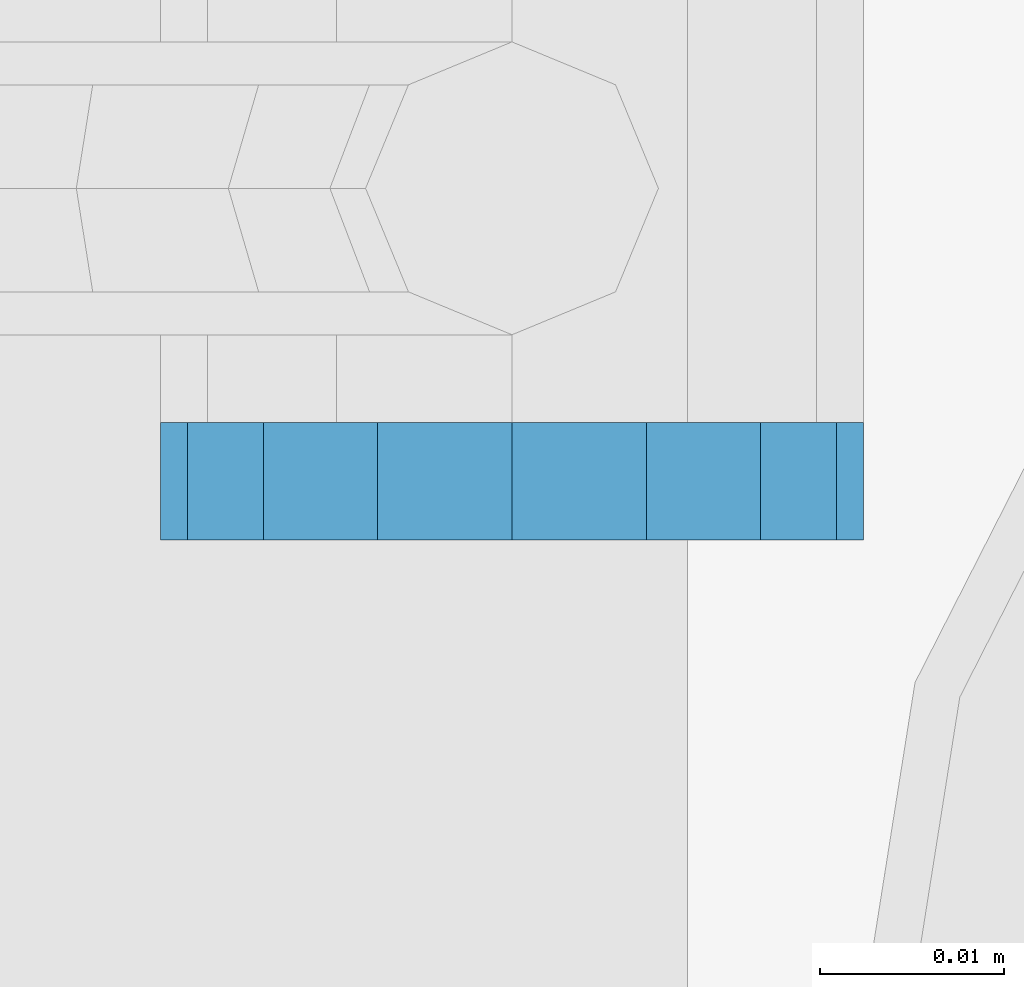
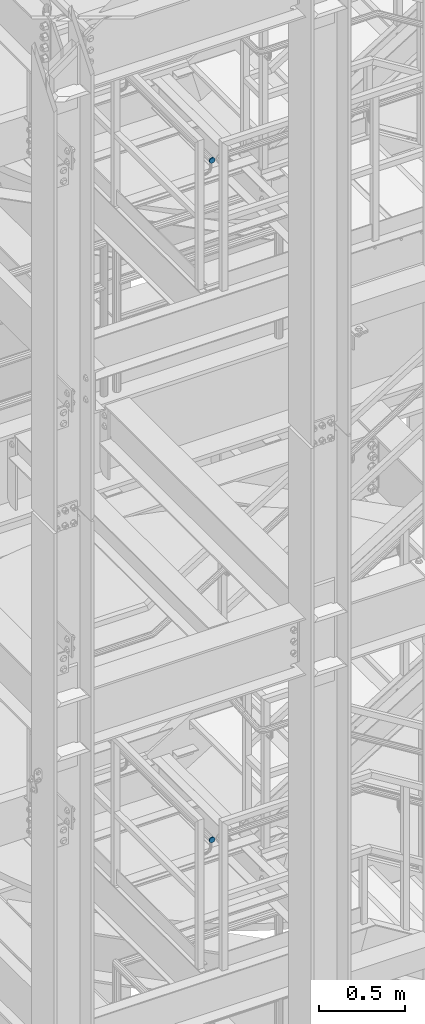
# One storey, part 1837 of 1876: 2 plates, 2 elements without a shape of their own.
"""IFC2X3 building model written with IfcOpenShell, lengths in millimetres."""

from ifc_helpers import new_model, si_unit, frame, origin_with_axes, place, context, subcontext, project, spatial, faceted_brep, material, type_object, element, aggregate, save


model = new_model("IFC2X3")

# Units and contexts
model_context = context("Model", 3, precision=1e-05, world=origin_with_axes())
body_context = subcontext(model_context, "Body", "Model", "MODEL_VIEW")
ifc_project = project(units=[si_unit("LENGTHUNIT", "METRE", prefix="MILLI"), si_unit("AREAUNIT", "SQUARE_METRE"), si_unit("VOLUMEUNIT", "CUBIC_METRE"), si_unit("MASSUNIT", "GRAM", prefix="KILO"), si_unit("TIMEUNIT", "SECOND"), si_unit("PLANEANGLEUNIT", "RADIAN"), si_unit("SOLIDANGLEUNIT", "STERADIAN"), si_unit("THERMODYNAMICTEMPERATUREUNIT", "DEGREE_CELSIUS"), si_unit("LUMINOUSINTENSITYUNIT", "LUMEN")], contexts=[model_context])

# Site, building, storey
site_placement = place(None, origin_with_axes())
site = spatial("IfcSite", under=ifc_project, at=site_placement, CompositionType="ELEMENT")
building_placement = place(site_placement, origin_with_axes())
building = spatial("IfcBuilding", under=site, at=building_placement, Name="Undefined", CompositionType="ELEMENT")
storey_placement = place(building_placement, origin_with_axes())
storey = spatial("IfcBuildingStorey", under=building, at=storey_placement, Name="Undefined", CompositionType="ELEMENT", Elevation=0.0)

# Assembly, plate
assembly_1_placement = place(storey_placement, origin_with_axes())
assembly_1 = element("IfcElementAssembly", 1, at=assembly_1_placement, inside=storey, Name="RAIL", AssemblyPlace="NOTDEFINED", PredefinedType="RIGID_FRAME")
ifc_material = material(Name="STEEL/A36")
plate_type = type_object("IfcPlateType", PredefinedType="NOTDEFINED")
plate_1_placement = place(assembly_1_placement, frame((1142.99999999374, -6835.7749774968, 16502.7316052369), z_axis=(0.0, 0.0, -1.0), x_axis=(1.0, 0.0, 0.0)))
plate_1 = element("IfcPlate", 2, at=plate_1_placement, type_object=plate_type, material=ifc_material, Name="PLATE", context=body_context, shape_type="Brep", body=[
    faceted_brep([(0.0, -3.17500000000018, 19.0499992370605), (1.45009484758475, -3.17500000000018, 26.3401183316528), (1.45009484758475, 3.17500000000018, 26.3401183316528), (0.0, 3.17500000000018, 19.0499992370605), (5.57961559493651, -3.17500000000018, 32.5203828791855), (5.57961559493651, 3.17500000000018, 32.5203828791855), (11.7598801424699, -3.17500000000018, 36.6499036265377), (11.7598801424699, 3.17500000000018, 36.6499036265377), (19.0499992370605, -3.17500000000018, 38.0999984741211), (19.0499992370605, 3.17500000000018, 38.0999984741211), (26.3401183316512, -3.17500000000018, 36.6499036265377), (26.3401183316512, 3.17500000000018, 36.6499036265377), (32.5203828791846, -3.17500000000018, 32.5203828791855), (32.5203828791846, 3.17500000000018, 32.5203828791855), (36.6499036265363, -3.17500000000018, 26.3401183316528), (36.6499036265363, 3.17500000000018, 26.3401183316528), (38.0999984741211, -3.17500000000018, 19.0499992370605), (38.0999984741211, 3.17500000000018, 19.0499992370605), (36.6499036265363, -3.17500000000018, 11.7598801424683), (36.6499036265363, 3.17500000000018, 11.7598801424683), (32.5203828791846, -3.17500000000018, 5.5796155949356), (32.5203828791846, 3.17500000000018, 5.5796155949356), (26.3401183316512, -3.17500000000018, 1.45009484758339), (26.3401183316512, 3.17500000000018, 1.45009484758339), (19.0499992370706, -3.17499999999745, -3.63797880709171e-12), (19.0499992370678, 3.17499999999836, 3.63797880709171e-12), (11.7598801424699, -3.17500000000018, 1.45009484758339), (11.7598801424699, 3.17500000000018, 1.45009484758339), (5.57961559493651, -3.17500000000018, 5.5796155949356), (5.57961559493651, 3.17500000000018, 5.5796155949356), (1.45009484758475, -3.17500000000018, 11.7598801424683), (1.45009484758475, 3.17500000000018, 11.7598801424683)], [[[0, 1, 2, 3]], [[1, 4, 5, 2]], [[4, 6, 7, 5]], [[6, 8, 9, 7]], [[8, 10, 11, 9]], [[10, 12, 13, 11]], [[12, 14, 15, 13]], [[14, 16, 17, 15]], [[16, 18, 19, 17]], [[18, 20, 21, 19]], [[20, 22, 23, 21]], [[22, 24, 25, 23]], [[24, 26, 27, 25]], [[26, 28, 29, 27]], [[28, 30, 31, 29]], [[30, 0, 3, 31]], [[5, 7, 9, 11, 13, 15, 17, 19, 21, 23, 25, 27, 29, 31, 3, 2]], [[30, 28, 26, 24, 22, 20, 18, 16, 14, 12, 10, 8, 6, 4, 1, 0]]]),
])
aggregate(assembly_1, [plate_1])

assembly_2_placement = place(storey_placement, origin_with_axes())
assembly_2 = element("IfcElementAssembly", 3, at=assembly_2_placement, inside=storey, Name="RAIL", AssemblyPlace="NOTDEFINED", PredefinedType="RIGID_FRAME")
plate_2_placement = place(assembly_2_placement, frame((1143.00000034225, -6835.7749774963, 11674.379753487), z_axis=(0.0, 0.0, -1.0), x_axis=(1.0, 0.0, 0.0)))
plate_2 = element("IfcPlate", 4, at=plate_2_placement, type_object=plate_type, material=ifc_material, Name="PLATE", context=body_context, shape_type="Brep", body=[
    faceted_brep([(0.0, -3.17500000000018, 19.0499992370605), (1.45009484758475, -3.17500000000018, 26.3401183316528), (1.45009484758475, 3.17500000000018, 26.3401183316528), (0.0, 3.17500000000018, 19.0499992370605), (5.57961559493651, -3.17500000000018, 32.5203828791855), (5.57961559493651, 3.17500000000018, 32.5203828791855), (11.7598801424699, -3.17500000000018, 36.6499036265377), (11.7598801424699, 3.17500000000018, 36.6499036265377), (19.0499992370605, -3.17500000000018, 38.0999984741211), (19.0499992370605, 3.17500000000018, 38.0999984741211), (26.3401183316512, -3.17500000000018, 36.6499036265377), (26.3401183316512, 3.17500000000018, 36.6499036265377), (32.5203828791846, -3.17500000000018, 32.5203828791855), (32.5203828791846, 3.17500000000018, 32.5203828791855), (36.6499036265363, -3.17500000000018, 26.3401183316528), (36.6499036265363, 3.17500000000018, 26.3401183316528), (38.0999984741211, -3.17500000000018, 19.0499992370605), (38.0999984741211, 3.17500000000018, 19.0499992370605), (36.6499036265363, -3.17500000000018, 11.7598801424683), (36.6499036265363, 3.17500000000018, 11.7598801424683), (32.5203828791846, -3.17500000000018, 5.5796155949356), (32.5203828791846, 3.17500000000018, 5.5796155949356), (26.3401183316512, -3.17500000000018, 1.45009484758339), (26.3401183316512, 3.17500000000018, 1.45009484758339), (19.0499992370706, -3.17499999999745, -3.63797880709171e-12), (19.0499992370678, 3.17499999999836, 3.63797880709171e-12), (11.7598801424699, -3.17500000000018, 1.45009484758339), (11.7598801424699, 3.17500000000018, 1.45009484758339), (5.57961559493651, -3.17500000000018, 5.5796155949356), (5.57961559493651, 3.17500000000018, 5.5796155949356), (1.45009484758475, -3.17500000000018, 11.7598801424683), (1.45009484758475, 3.17500000000018, 11.7598801424683)], [[[0, 1, 2, 3]], [[1, 4, 5, 2]], [[4, 6, 7, 5]], [[6, 8, 9, 7]], [[8, 10, 11, 9]], [[10, 12, 13, 11]], [[12, 14, 15, 13]], [[14, 16, 17, 15]], [[16, 18, 19, 17]], [[18, 20, 21, 19]], [[20, 22, 23, 21]], [[22, 24, 25, 23]], [[24, 26, 27, 25]], [[26, 28, 29, 27]], [[28, 30, 31, 29]], [[30, 0, 3, 31]], [[5, 7, 9, 11, 13, 15, 17, 19, 21, 23, 25, 27, 29, 31, 3, 2]], [[30, 28, 26, 24, 22, 20, 18, 16, 14, 12, 10, 8, 6, 4, 1, 0]]]),
])
aggregate(assembly_2, [plate_2])

save(model, "model.ifc")
